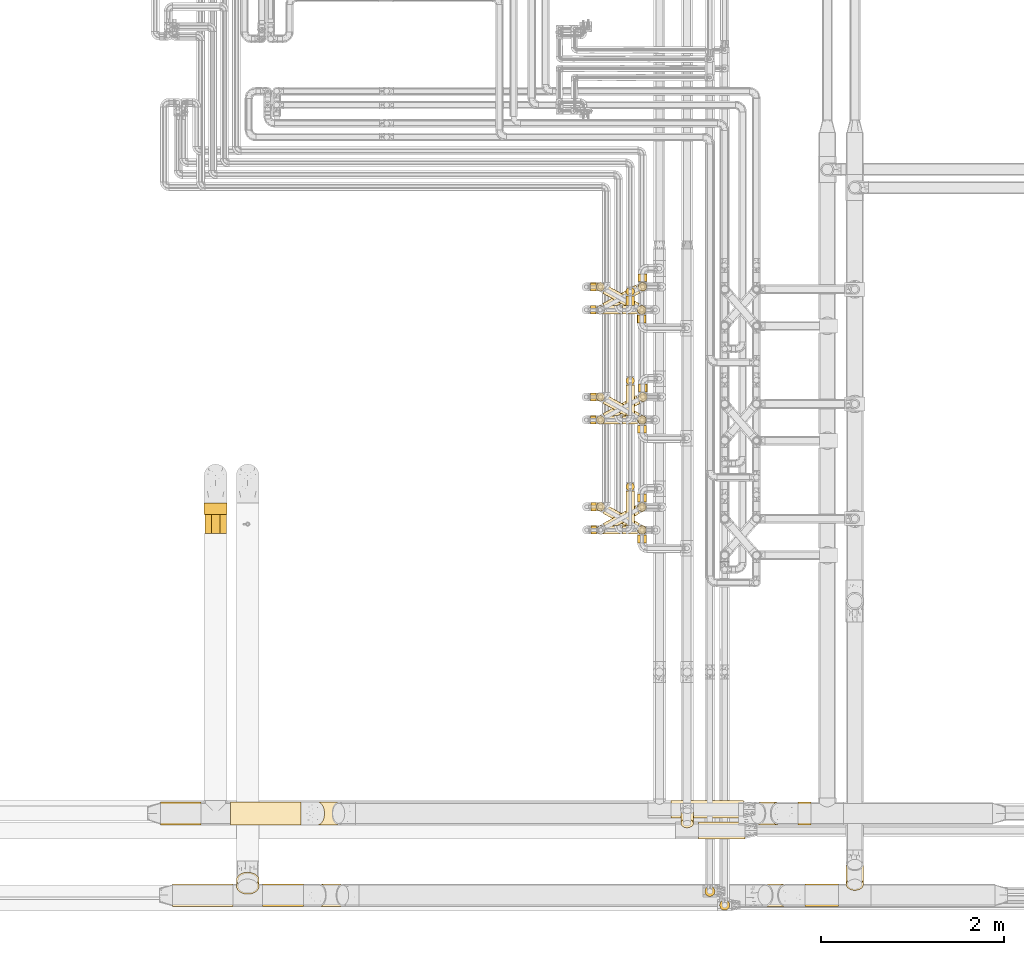
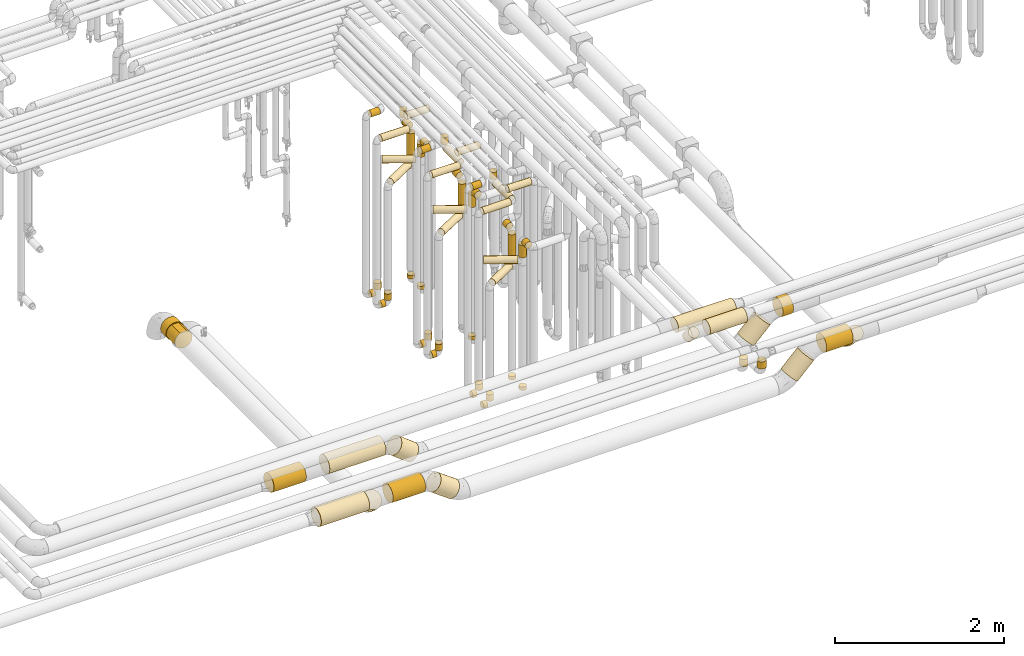
# One storey, part 11 of 824: 69 coverings.
"""IFC2X3 building model written with IfcOpenShell, lengths in millimetres."""

from ifc_helpers import new_model, entity, si_unit, converted_unit, derived_unit, direction, frame, frame_2d, origin, origin_2d_with_axis, place, context, subcontext, project, spatial, polyline, circle_curve, parameter, trimmed, segment, composite_curve, circle, outline, extrude, element, save


model = new_model("IFC2X3")

# Units and contexts
model_context = context("Model", 3, precision=0.01, world=origin(), true_north=direction((6.12303176911189e-17, 1.0)))
body_context = subcontext(model_context, "Body", "Model", "MODEL_VIEW")
ifc_project = project(units=[si_unit("LENGTHUNIT", "METRE", prefix="MILLI"), si_unit("AREAUNIT", "SQUARE_METRE"), si_unit("VOLUMEUNIT", "CUBIC_METRE"), converted_unit("PLANEANGLEUNIT", "DEGREE", entity("IfcRatioMeasure", 0.0174532925199433), si_unit("PLANEANGLEUNIT", "RADIAN"), dimensions=[0, 0, 0, 0, 0, 0, 0]), si_unit("MASSUNIT", "GRAM", prefix="KILO"), derived_unit("MASSDENSITYUNIT", [(si_unit("MASSUNIT", "GRAM", prefix="KILO"), 1), (si_unit("LENGTHUNIT", "METRE"), -3)]), derived_unit("MOMENTOFINERTIAUNIT", [(si_unit("LENGTHUNIT", "METRE"), 4)]), si_unit("TIMEUNIT", "SECOND"), si_unit("FREQUENCYUNIT", "HERTZ"), si_unit("THERMODYNAMICTEMPERATUREUNIT", "DEGREE_CELSIUS"), derived_unit("THERMALTRANSMITTANCEUNIT", [(si_unit("MASSUNIT", "GRAM", prefix="KILO"), 1), (si_unit("THERMODYNAMICTEMPERATUREUNIT", "KELVIN"), -1), (si_unit("TIMEUNIT", "SECOND"), -3)]), derived_unit("VOLUMETRICFLOWRATEUNIT", [(si_unit("LENGTHUNIT", "METRE"), 3), (si_unit("TIMEUNIT", "SECOND"), -1)]), derived_unit("MASSFLOWRATEUNIT", [(si_unit("MASSUNIT", "GRAM", prefix="KILO"), 1), (si_unit("TIMEUNIT", "SECOND"), -1)]), derived_unit("ROTATIONALFREQUENCYUNIT", [(si_unit("TIMEUNIT", "SECOND"), -1)]), si_unit("ELECTRICCURRENTUNIT", "AMPERE"), si_unit("ELECTRICVOLTAGEUNIT", "VOLT"), si_unit("POWERUNIT", "WATT"), si_unit("FORCEUNIT", "NEWTON", prefix="KILO"), si_unit("ILLUMINANCEUNIT", "LUX"), si_unit("LUMINOUSFLUXUNIT", "LUMEN"), si_unit("LUMINOUSINTENSITYUNIT", "CANDELA"), derived_unit("USERDEFINED", [(si_unit("MASSUNIT", "GRAM", prefix="KILO"), -1), (si_unit("LENGTHUNIT", "METRE"), -2), (si_unit("TIMEUNIT", "SECOND"), 3), (si_unit("LUMINOUSFLUXUNIT", "LUMEN"), 1)]), derived_unit("LINEARVELOCITYUNIT", [(si_unit("LENGTHUNIT", "METRE"), 1), (si_unit("TIMEUNIT", "SECOND"), -1)]), si_unit("PRESSUREUNIT", "PASCAL"), derived_unit("USERDEFINED", [(si_unit("LENGTHUNIT", "METRE"), -2), (si_unit("MASSUNIT", "GRAM", prefix="KILO"), 1), (si_unit("TIMEUNIT", "SECOND"), -2)]), derived_unit("LINEARFORCEUNIT", [(si_unit("MASSUNIT", "GRAM", prefix="KILO"), 1), (si_unit("LENGTHUNIT", "METRE"), 1), (si_unit("TIMEUNIT", "SECOND"), -2), (si_unit("LENGTHUNIT", "METRE"), -1)]), derived_unit("PLANARFORCEUNIT", [(si_unit("MASSUNIT", "GRAM", prefix="KILO"), 1), (si_unit("LENGTHUNIT", "METRE"), 1), (si_unit("TIMEUNIT", "SECOND"), -2), (si_unit("LENGTHUNIT", "METRE"), -2)])], contexts=[model_context])

# Site, building, storey
site_placement = place(None, origin())
site = spatial("IfcSite", under=ifc_project, at=site_placement, CompositionType="ELEMENT")
building_placement = place(site_placement, origin())
building = spatial("IfcBuilding", under=site, at=building_placement, CompositionType="ELEMENT")
storey_placement = place(building_placement, frame((0.0, 0.0, 28200.0)))
storey = spatial("IfcBuildingStorey", under=building, at=storey_placement, CompositionType="ELEMENT", Elevation=28200.0)

# Coverings
covering_1_placement = place(storey_placement, frame((35168.03, 11508.46, 352.25)))
element("IfcCovering", 1, at=covering_1_placement, inside=storey, PredefinedType="INSULATION", context=body_context, shape_type="SweptSolid", body=[
    extrude(circle(Radius=46.15, at=origin_2d_with_axis()), frame((0.0, 47.75, 47.75), z_axis=(1.0, 0.0, 0.0), x_axis=(0.0, 1.0, 0.0)), (0.0, 0.0, 1.0), 59.0000000000126),
])
covering_2_placement = place(storey_placement, frame((35227.29, 11508.46, 448.0)))
element("IfcCovering", 2, at=covering_2_placement, inside=storey, PredefinedType="INSULATION", context=body_context, shape_type="SweptSolid", body=[
    extrude(circle(Radius=46.15, at=origin_2d_with_axis()), frame((47.75, 47.75, 0.0), z_axis=(0.0, 0.0, 1.0), x_axis=(0.0, 1.0, 0.0)), (0.0, 0.0, 1.0), 92.0000000000137),
])
covering_3_placement = place(storey_placement, frame((35173.03, 10309.34, 352.25)))
element("IfcCovering", 3, at=covering_3_placement, inside=storey, PredefinedType="INSULATION", context=body_context, shape_type="SweptSolid", body=[
    extrude(circle(Radius=46.15, at=origin_2d_with_axis()), frame((0.0, 47.75, 47.75), z_axis=(1.0, 0.0, 0.0), x_axis=(0.0, 1.0, 0.0)), (0.0, 0.0, 1.0), 57.8337402419765),
])
covering_4_placement = place(storey_placement, frame((35231.12, 10309.34, 448.0)))
element("IfcCovering", 4, at=covering_4_placement, inside=storey, PredefinedType="INSULATION", context=body_context, shape_type="SweptSolid", body=[
    extrude(circle(Radius=46.15, at=origin_2d_with_axis()), frame((47.75, 47.75, 0.0), z_axis=(0.0, 0.0, 1.0), x_axis=(0.0, 1.0, 0.0)), (0.0, 0.0, 1.0), 92.0000000000137),
])
covering_5_placement = place(storey_placement, frame((35680.3, 10558.46, 448.0)))
element("IfcCovering", 5, at=covering_5_placement, inside=storey, PredefinedType="INSULATION", context=body_context, shape_type="SweptSolid", body=[
    extrude(circle(Radius=46.15, at=origin_2d_with_axis()), frame((47.75, 47.75, 0.0), z_axis=(0.0, 0.0, 1.0), x_axis=(0.0, -1.0, 0.0)), (0.0, 0.0, 1.0), 47.000000000011),
])
covering_6_placement = place(storey_placement, frame((35168.03, 11508.44, 2952.25)))
element("IfcCovering", 6, at=covering_6_placement, inside=storey, PredefinedType="INSULATION", context=body_context, shape_type="SweptSolid", body=[
    extrude(circle(Radius=46.15, at=origin_2d_with_axis()), frame((0.0, 47.76, 47.75), z_axis=(1.0, -4.58022354030143e-05, 0.0), x_axis=(-4.58022354030143e-05, -1.0, 0.0)), (0.0, 0.0, 1.0), 384.054937940216),
])
covering_7_placement = place(storey_placement, frame((35552.35, 11604.18, 2952.25)))
element("IfcCovering", 7, at=covering_7_placement, inside=storey, PredefinedType="INSULATION", context=body_context, shape_type="SweptSolid", body=[
    extrude(circle(Radius=46.15, at=origin_2d_with_axis()), frame((47.75, 0.0, 47.75), z_axis=(0.0, 1.0, 0.0), x_axis=(1.0, 0.0, 0.0)), (0.0, 0.0, 1.0), 331.019903361197),
])
covering_8_placement = place(storey_placement, frame((35552.35, 11935.46, 3048.0)))
element("IfcCovering", 8, at=covering_8_placement, inside=storey, PredefinedType="INSULATION", context=body_context, shape_type="SweptSolid", body=[
    extrude(circle(Radius=46.15, at=origin_2d_with_axis()), frame((47.75, 47.75, 0.0), z_axis=(0.0, 0.0, 1.0), x_axis=(-1.0, 0.0, 0.0)), (0.0, 0.0, 1.0), 104.000000000011),
])
covering_9_placement = place(storey_placement, frame((35677.45, 10555.61, 2157.0)))
element("IfcCovering", 9, at=covering_9_placement, inside=storey, PredefinedType="INSULATION", context=body_context, shape_type="SweptSolid", body=[
    extrude(circle(Radius=49.0, at=origin_2d_with_axis()), frame((50.6, 50.6, 0.0)), (0.0, 0.0, 1.0), 385.99999999999),
])
covering_10_placement = place(storey_placement, frame((35303.27, 10340.38, 2049.4)))
element("IfcCovering", 10, at=covering_10_placement, inside=storey, PredefinedType="INSULATION", context=body_context, shape_type="SweptSolid", body=[
    extrude(circle(Radius=49.0, at=origin_2d_with_axis()), frame((25.41, 44.42, 50.6), z_axis=(0.873900740639492, 0.486104408033651, 0.0), x_axis=(0.486104408033651, -0.873900740639492, 0.0)), (0.0, 0.0, 1.0), 399.639020319073),
])
covering_11_placement = place(storey_placement, frame((35677.45, 10663.2, 2549.4)))
element("IfcCovering", 11, at=covering_11_placement, inside=storey, PredefinedType="INSULATION", context=body_context, shape_type="SweptSolid", body=[
    extrude(circle(Radius=49.0, at=origin_2d_with_axis()), frame((50.6, 0.0, 50.6), z_axis=(0.0, 1.0, 0.0), x_axis=(-1.0, 0.0, 0.0)), (0.0, 0.0, 1.0), 85.9999999262502),
])
covering_12_placement = place(storey_placement, frame((35686.28, 11755.09, 2157.0)))
element("IfcCovering", 12, at=covering_12_placement, inside=storey, PredefinedType="INSULATION", context=body_context, shape_type="SweptSolid", body=[
    extrude(circle(Radius=49.0, at=origin_2d_with_axis()), frame((50.58, 50.58, 0.0), z_axis=(0.0, 0.0, 1.0), x_axis=(0.47617625102764, -0.879349860952546, 0.0)), (0.0, 0.0, 1.0), 385.99999999999),
])
covering_13_placement = place(storey_placement, frame((35300.25, 11538.06, 2049.4)))
element("IfcCovering", 13, at=covering_13_placement, inside=storey, PredefinedType="INSULATION", context=body_context, shape_type="SweptSolid", body=[
    extrude(circle(Radius=49.0, at=origin_2d_with_axis()), frame((24.93, 44.68, 50.6), z_axis=(0.879349860952551, 0.47617625102763, 0.0), x_axis=(-0.47617625102763, 0.879349860952551, 0.0)), (0.0, 0.0, 1.0), 411.156212335708),
])
covering_14_placement = place(storey_placement, frame((35686.26, 11862.67, 2549.4)))
element("IfcCovering", 14, at=covering_14_placement, inside=storey, PredefinedType="INSULATION", context=body_context, shape_type="SweptSolid", body=[
    extrude(circle(Radius=49.0, at=origin_2d_with_axis()), frame((50.6, 0.0, 50.6), z_axis=(0.0, 1.0, 0.0), x_axis=(-1.0, 0.0, 0.0)), (0.0, 0.0, 1.0), 86.4113062809591),
])
covering_15_placement = place(storey_placement, frame((35683.56, 12960.1, 2157.0)))
element("IfcCovering", 15, at=covering_15_placement, inside=storey, PredefinedType="INSULATION", context=body_context, shape_type="SweptSolid", body=[
    extrude(circle(Radius=49.0, at=origin_2d_with_axis()), frame((50.58, 50.58, 0.0), z_axis=(0.0, 0.0, 1.0), x_axis=(0.47617625102764, -0.879349860952546, 0.0)), (0.0, 0.0, 1.0), 385.999999999986),
])
covering_16_placement = place(storey_placement, frame((35297.3, 12738.15, 2049.4)))
element("IfcCovering", 16, at=covering_16_placement, inside=storey, PredefinedType="INSULATION", context=body_context, shape_type="SweptSolid", body=[
    extrude(circle(Radius=49.0, at=origin_2d_with_axis()), frame((25.41, 44.42, 50.6), z_axis=(0.873900740639491, 0.486104408033654, 0.0), x_axis=(-0.486104408033654, 0.873900740639491, 0.0)), (0.0, 0.0, 1.0), 413.435297220392),
])
covering_17_placement = place(storey_placement, frame((35683.65, 13067.49, 2549.4)))
element("IfcCovering", 17, at=covering_17_placement, inside=storey, PredefinedType="INSULATION", context=body_context, shape_type="SweptSolid", body=[
    extrude(circle(Radius=49.0, at=origin_2d_with_axis()), frame((50.6, 0.0, 50.6), z_axis=(0.0, 1.0, 0.0), x_axis=(-1.0, 0.0, 0.0)), (0.0, 0.0, 1.0), 81.5902938725307),
])
covering_18_placement = place(storey_placement, frame((35552.35, 10780.63, 3248.0)))
element("IfcCovering", 18, at=covering_18_placement, inside=storey, PredefinedType="INSULATION", context=body_context, shape_type="SweptSolid", body=[
    extrude(circle(Radius=46.15, at=origin_2d_with_axis()), frame((47.75, 47.75, 0.0), z_axis=(0.0, 0.0, 1.0), x_axis=(-1.0, 0.0, 0.0)), (0.0, 0.0, 1.0), 103.999999999998),
])
covering_19_placement = place(storey_placement, frame((35552.35, 10405.08, 3152.25)))
element("IfcCovering", 19, at=covering_19_placement, inside=storey, PredefinedType="INSULATION", context=body_context, shape_type="SweptSolid", body=[
    extrude(circle(Radius=46.15, at=origin_2d_with_axis()), frame((47.75, 0.0, 47.75), z_axis=(0.0, 1.0, 0.0), x_axis=(-1.0, 0.0, 0.0)), (0.0, 0.0, 1.0), 375.292233723899),
])
covering_20_placement = place(storey_placement, frame((35173.03, 10309.34, 3152.25)))
element("IfcCovering", 20, at=covering_20_placement, inside=storey, PredefinedType="INSULATION", context=body_context, shape_type="SweptSolid", body=[
    extrude(circle(Radius=46.15, at=origin_2d_with_axis()), frame((0.0, 47.75, 47.75), z_axis=(1.0, 0.0, 0.0), x_axis=(0.0, 1.0, 0.0)), (0.0, 0.0, 1.0), 379.057450000017),
])
covering_21_placement = place(storey_placement, frame((35168.03, 11758.46, 352.25)))
element("IfcCovering", 21, at=covering_21_placement, inside=storey, PredefinedType="INSULATION", context=body_context, shape_type="SweptSolid", body=[
    extrude(circle(Radius=46.15, at=origin_2d_with_axis()), frame((0.0, 47.75, 47.75), z_axis=(1.0, 0.0, 0.0), x_axis=(0.0, 1.0, 0.0)), (0.0, 0.0, 1.0), 60.205336192978),
])
covering_22_placement = place(storey_placement, frame((35228.49, 11758.46, 448.0)))
element("IfcCovering", 22, at=covering_22_placement, inside=storey, PredefinedType="INSULATION", context=body_context, shape_type="SweptSolid", body=[
    extrude(circle(Radius=46.15, at=origin_2d_with_axis()), frame((47.75, 47.75, 0.0), z_axis=(0.0, 0.0, 1.0), x_axis=(0.0, 1.0, 0.0)), (0.0, 0.0, 1.0), 92.0000000000094),
])
covering_23_placement = place(storey_placement, frame((35681.04, 11508.42, 447.94)))
element("IfcCovering", 23, at=covering_23_placement, inside=storey, PredefinedType="INSULATION", context=body_context, shape_type="SweptSolid", body=[
    extrude(circle(Radius=46.15, at=origin_2d_with_axis()), frame((47.75, 47.75, 0.06), z_axis=(0.0, 0.00137558663897165, 0.999999053880252), x_axis=(0.0, 0.999999053880252, -0.00137558663897165)), (0.0, 0.0, 1.0), 47.0000771237188),
])
covering_24_placement = place(storey_placement, frame((35173.03, 10561.4, 352.25)))
element("IfcCovering", 24, at=covering_24_placement, inside=storey, PredefinedType="INSULATION", context=body_context, shape_type="SweptSolid", body=[
    extrude(circle(Radius=46.15, at=origin_2d_with_axis()), frame((0.0, 47.75, 47.75), z_axis=(1.0, 0.0, 0.0), x_axis=(0.0, 1.0, 0.0)), (0.0, 0.0, 1.0), 55.7044279710415),
])
covering_25_placement = place(storey_placement, frame((35228.99, 10561.4, 448.0)))
element("IfcCovering", 25, at=covering_25_placement, inside=storey, PredefinedType="INSULATION", context=body_context, shape_type="SweptSolid", body=[
    extrude(circle(Radius=46.15, at=origin_2d_with_axis()), frame((47.75, 47.75, 0.0), z_axis=(0.0, 0.0, 1.0), x_axis=(0.0, 1.0, 0.0)), (0.0, 0.0, 1.0), 92.0000000000094),
])
covering_26_placement = place(storey_placement, frame((35680.3, 10308.42, 448.0)))
element("IfcCovering", 26, at=covering_26_placement, inside=storey, PredefinedType="INSULATION", context=body_context, shape_type="SweptSolid", body=[
    extrude(circle(Radius=46.15, at=origin_2d_with_axis()), frame((47.75, 47.75, 0.0), z_axis=(0.0, 0.0, 1.0), x_axis=(0.0, -1.0, 0.0)), (0.0, 0.0, 1.0), 47.0000000000153),
])
covering_27_placement = place(storey_placement, frame((36344.03, 6983.4, 3003.4)))
element("IfcCovering", 27, at=covering_27_placement, inside=storey, PredefinedType="INSULATION", context=body_context, shape_type="SweptSolid", body=[
    extrude(circle(Radius=95.0, at=origin_2d_with_axis()), frame((0.0, 96.6, 96.6), z_axis=(1.0, 0.0, 0.0), x_axis=(0.0, -1.0, 0.0)), (0.0, 0.0, 1.0), 508.799297490111),
])
covering_28_placement = place(storey_placement, frame((35168.03, 11758.46, 3152.25)))
element("IfcCovering", 28, at=covering_28_placement, inside=storey, PredefinedType="INSULATION", context=body_context, shape_type="SweptSolid", body=[
    extrude(circle(Radius=46.15, at=origin_2d_with_axis()), frame((0.0, 47.75, 47.75), z_axis=(1.0, 0.0, 0.0), x_axis=(0.0, 1.0, 0.0)), (0.0, 0.0, 1.0), 124.000000000024),
])
covering_29_placement = place(storey_placement, frame((35518.03, 11508.42, 3152.25)))
element("IfcCovering", 29, at=covering_29_placement, inside=storey, PredefinedType="INSULATION", context=body_context, shape_type="SweptSolid", body=[
    extrude(circle(Radius=46.15, at=origin_2d_with_axis()), frame((0.0, 47.75, 47.75), z_axis=(1.0, 0.0, 0.0), x_axis=(0.0, -1.0, 0.0)), (0.0, 0.0, 1.0), 307.750000000047),
])
covering_30_placement = place(storey_placement, frame((35677.45, 10305.57, 2362.0)))
element("IfcCovering", 30, at=covering_30_placement, inside=storey, PredefinedType="INSULATION", context=body_context, shape_type="SweptSolid", body=[
    extrude(circle(Radius=49.0, at=origin_2d_with_axis()), frame((50.6, 50.6, 0.0)), (0.0, 0.0, 1.0), 181.000000000002),
])
covering_31_placement = place(storey_placement, frame((35300.91, 10339.7, 2254.4)))
element("IfcCovering", 31, at=covering_31_placement, inside=storey, PredefinedType="INSULATION", context=body_context, shape_type="SweptSolid", body=[
    extrude(circle(Radius=49.0, at=origin_2d_with_axis()), frame((25.55, 241.55, 50.6), z_axis=(0.872328835264981, -0.488919628533404, 0.0), x_axis=(-0.488919628533404, -0.872328835264981, 0.0)), (0.0, 0.0, 1.0), 403.365689374244),
])
covering_32_placement = place(storey_placement, frame((35677.45, 10213.2, 2549.4)))
element("IfcCovering", 32, at=covering_32_placement, inside=storey, PredefinedType="INSULATION", context=body_context, shape_type="SweptSolid", body=[
    extrude(circle(Radius=49.0, at=origin_2d_with_axis()), frame((50.6, 0.0, 50.6), z_axis=(0.0, 1.0, 0.0), x_axis=(1.0, 0.0, 0.0)), (0.0, 0.0, 1.0), 85.9654132835041),
])
covering_33_placement = place(storey_placement, frame((35678.19, 11503.87, 2362.0)))
element("IfcCovering", 33, at=covering_33_placement, inside=storey, PredefinedType="INSULATION", context=body_context, shape_type="SweptSolid", body=[
    extrude(circle(Radius=49.0, at=origin_2d_with_axis()), frame((50.59, 50.59, 0.0), z_axis=(0.0, 0.0, 1.0), x_axis=(-0.494757339901244, -0.869031170104873, 0.0)), (0.0, 0.0, 1.0), 180.999999999998),
])
covering_34_placement = place(storey_placement, frame((35300.46, 11538.31, 2254.4)))
element("IfcCovering", 34, at=covering_34_placement, inside=storey, PredefinedType="INSULATION", context=body_context, shape_type="SweptSolid", body=[
    extrude(circle(Radius=49.0, at=origin_2d_with_axis()), frame((25.52, 241.99, 50.6), z_axis=(0.872709848733326, -0.488239203591698, 0.0), x_axis=(0.488239203591698, 0.872709848733326, 0.0)), (0.0, 0.0, 1.0), 404.791381976554),
])
covering_35_placement = place(storey_placement, frame((35678.19, 11413.08, 2549.4)))
element("IfcCovering", 35, at=covering_35_placement, inside=storey, PredefinedType="INSULATION", context=body_context, shape_type="SweptSolid", body=[
    extrude(circle(Radius=49.0, at=origin_2d_with_axis()), frame((50.6, 0.0, 50.6), z_axis=(0.0, 1.0, 0.0), x_axis=(1.0, 0.0, 0.0)), (0.0, 0.0, 1.0), 84.3822522691391),
])
covering_36_placement = place(storey_placement, frame((35674.65, 12704.08, 2362.0)))
element("IfcCovering", 36, at=covering_36_placement, inside=storey, PredefinedType="INSULATION", context=body_context, shape_type="SweptSolid", body=[
    extrude(circle(Radius=49.0, at=origin_2d_with_axis()), frame((50.38, 50.38, 0.0), z_axis=(0.0, 0.0, 1.0), x_axis=(-0.579093053123268, -0.81526145243374, 0.0)), (0.0, 0.0, 1.0), 180.999999999993),
])
covering_37_placement = place(storey_placement, frame((35299.57, 12738.31, 2254.4)))
element("IfcCovering", 37, at=covering_37_placement, inside=storey, PredefinedType="INSULATION", context=body_context, shape_type="SweptSolid", body=[
    extrude(circle(Radius=49.0, at=origin_2d_with_axis()), frame((25.52, 240.4, 50.6), z_axis=(0.872709832917215, -0.488239231862421, 0.0), x_axis=(0.488239231862421, 0.872709832917215, 0.0)), (0.0, 0.0, 1.0), 401.518720143664),
])
covering_38_placement = place(storey_placement, frame((35674.44, 12613.08, 2549.4)))
element("IfcCovering", 38, at=covering_38_placement, inside=storey, PredefinedType="INSULATION", context=body_context, shape_type="SweptSolid", body=[
    extrude(circle(Radius=49.0, at=origin_2d_with_axis()), frame((50.6, 0.0, 50.6), z_axis=(0.0, 1.0, 0.0), x_axis=(1.0, 0.0, 0.0)), (0.0, 0.0, 1.0), 84.38225226915),
])
covering_39_placement = place(storey_placement, frame((35173.03, 10561.4, 3352.25)))
element("IfcCovering", 39, at=covering_39_placement, inside=storey, PredefinedType="INSULATION", context=body_context, shape_type="SweptSolid", body=[
    extrude(circle(Radius=46.15, at=origin_2d_with_axis()), frame((0.0, 47.75, 47.75), z_axis=(1.0, 0.0, 0.0), x_axis=(0.0, 1.0, 0.0)), (0.0, 0.0, 1.0), 119.000000000016),
])
covering_40_placement = place(storey_placement, frame((35518.03, 10308.42, 3352.25)))
element("IfcCovering", 40, at=covering_40_placement, inside=storey, PredefinedType="INSULATION", context=body_context, shape_type="SweptSolid", body=[
    extrude(circle(Radius=46.15, at=origin_2d_with_axis()), frame((0.0, 47.75, 47.75), z_axis=(1.0, 0.0, 0.0), x_axis=(0.0, 1.0, 0.0)), (0.0, 0.0, 1.0), 312.75000000005),
])
covering_41_placement = place(storey_placement, frame((35168.03, 12708.46, 352.25)))
element("IfcCovering", 41, at=covering_41_placement, inside=storey, PredefinedType="INSULATION", context=body_context, shape_type="SweptSolid", body=[
    extrude(circle(Radius=46.15, at=origin_2d_with_axis()), frame((0.0, 47.75, 47.75), z_axis=(1.0, 0.0, 0.0), x_axis=(0.0, 1.0, 0.0)), (0.0, 0.0, 1.0), 56.8702533571783),
])
covering_42_placement = place(storey_placement, frame((35225.16, 12708.46, 448.0)))
element("IfcCovering", 42, at=covering_42_placement, inside=storey, PredefinedType="INSULATION", context=body_context, shape_type="SweptSolid", body=[
    extrude(circle(Radius=46.15, at=origin_2d_with_axis()), frame((47.75, 47.75, 0.0), z_axis=(0.0, 0.0, 1.0), x_axis=(0.0, 1.0, 0.0)), (0.0, 0.0, 1.0), 92.0000000000094),
])
covering_43_placement = place(storey_placement, frame((35552.35, 12908.43, 2847.61)))
element("IfcCovering", 43, at=covering_43_placement, inside=storey, PredefinedType="INSULATION", context=body_context, shape_type="SweptSolid", body=[
    extrude(circle(Radius=46.15, at=origin_2d_with_axis()), frame((47.75, 47.75, 0.0), z_axis=(0.0, 0.0, 1.0), x_axis=(-1.0, 0.0, 0.0)), (0.0, 0.0, 1.0), 104.39114387437),
])
covering_44_placement = place(storey_placement, frame((35552.35, 12804.17, 2751.86)))
element("IfcCovering", 44, at=covering_44_placement, inside=storey, PredefinedType="INSULATION", context=body_context, shape_type="SweptSolid", body=[
    extrude(circle(Radius=46.15, at=origin_2d_with_axis()), frame((47.75, 0.0, 47.75), z_axis=(0.0, 1.0, 0.0), x_axis=(1.0, 0.0, 0.0)), (0.0, 0.0, 1.0), 104.000000000018),
])
covering_45_placement = place(storey_placement, frame((35168.03, 12708.43, 2751.86)))
element("IfcCovering", 45, at=covering_45_placement, inside=storey, PredefinedType="INSULATION", context=body_context, shape_type="SweptSolid", body=[
    extrude(circle(Radius=46.15, at=origin_2d_with_axis()), frame((0.0, 47.77, 47.75), z_axis=(0.999999997789185, -6.64953413086212e-05, 0.0), x_axis=(6.64953413086212e-05, 0.999999997789185, 0.0)), (0.0, 0.0, 1.0), 384.054259178842),
])
covering_46_placement = place(storey_placement, frame((35518.03, 12708.42, 2952.25)))
element("IfcCovering", 46, at=covering_46_placement, inside=storey, PredefinedType="INSULATION", context=body_context, shape_type="SweptSolid", body=[
    extrude(circle(Radius=46.15, at=origin_2d_with_axis()), frame((0.0, 47.75, 47.75), z_axis=(1.0, 0.0, 0.0), x_axis=(0.0, 1.0, 0.0)), (0.0, 0.0, 1.0), 307.750000000012),
])
for number, where in (
    (47, (35677.29, 12708.42, 448.0)),
    (48, (35686.39, 12958.46, 448.0)),
):
    element("IfcCovering", number, at=place(storey_placement, frame(where)), inside=storey, PredefinedType="INSULATION", context=body_context, shape_type="SweptSolid", body=[
        extrude(circle(Radius=46.15, at=origin_2d_with_axis()), frame((47.75, 47.75, 0.0), z_axis=(0.0, 0.0, 1.0), x_axis=(0.0, -1.0, 0.0)), (0.0, 0.0, 1.0), 47.000000000011),
    ])
covering_47_placement = place(storey_placement, frame((35168.03, 12958.46, 2952.25)))
element("IfcCovering", 49, at=covering_47_placement, inside=storey, PredefinedType="INSULATION", context=body_context, shape_type="SweptSolid", body=[
    extrude(circle(Radius=46.15, at=origin_2d_with_axis()), frame((0.0, 47.75, 47.75), z_axis=(1.0, 0.0, 0.0), x_axis=(0.0, -1.0, 0.0)), (0.0, 0.0, 1.0), 124.000000000015),
])
covering_48_placement = place(storey_placement, frame((35168.03, 12958.46, 352.25)))
element("IfcCovering", 50, at=covering_48_placement, inside=storey, PredefinedType="INSULATION", context=body_context, shape_type="SweptSolid", body=[
    extrude(circle(Radius=46.15, at=origin_2d_with_axis()), frame((0.0, 47.75, 47.75), z_axis=(1.0, 0.0, 0.0), x_axis=(0.0, 1.0, 0.0)), (0.0, 0.0, 1.0), 59.3114268710131),
])
covering_49_placement = place(storey_placement, frame((35227.6, 12958.46, 448.0)))
element("IfcCovering", 51, at=covering_49_placement, inside=storey, PredefinedType="INSULATION", context=body_context, shape_type="SweptSolid", body=[
    extrude(circle(Radius=46.15, at=origin_2d_with_axis()), frame((47.75, 47.75, 0.0), z_axis=(0.0, 0.0, 1.0), x_axis=(0.0, 1.0, 0.0)), (0.0, 0.0, 1.0), 92.0000000000094),
])
covering_50_placement = place(storey_placement, frame((30953.9, 10524.83, 2673.9)))
element("IfcCovering", 52, at=covering_50_placement, inside=storey, PredefinedType="INSULATION", context=body_context, shape_type="SweptSolid", body=[
    extrude(outline(polyline([(-16.25, -123.43), (16.25, -123.43), (47.64, -115.02), (75.79, -98.77), (98.77, -75.79), (115.02, -47.64), (123.43, -16.25), (123.43, 16.25), (115.02, 47.64), (98.77, 75.79), (75.79, 98.77), (47.64, 115.02), (16.25, 123.43), (-16.25, 123.43), (-47.64, 115.02), (-75.79, 98.77), (-98.77, 75.79), (-115.02, 47.64), (-123.43, 16.25), (-123.43, -16.25), (-115.02, -47.64), (-98.77, -75.79), (-75.79, -98.77), (-47.64, -115.02), (-16.25, -123.43)])), frame((126.1, 0.0, 126.1), z_axis=(3.15716611416897e-09, 1.0, 0.0), x_axis=(-0.130526192220075, 0.0, -0.991444861373807)), (0.0, 0.0, 1.0), 125.173920988328),
])
covering_51_placement = place(storey_placement, frame((30479.76, 7140.11, 2673.9)))
element("IfcCovering", 53, at=covering_51_placement, inside=storey, PredefinedType="INSULATION", context=body_context, shape_type="SweptSolid", body=[
    extrude(circle(Radius=124.5, at=origin_2d_with_axis()), frame((0.0, 126.1, 126.1), z_axis=(1.0, 0.0, -2.62756642280565e-06), x_axis=(0.0, -1.0, 0.0)), (0.0, 0.0, 1.0), 440.240643086704),
])
covering_52_placement = place(storey_placement, frame((31240.0, 7140.11, 2673.9)))
element("IfcCovering", 54, at=covering_52_placement, inside=storey, PredefinedType="INSULATION", context=body_context, shape_type="SweptSolid", body=[
    extrude(circle(Radius=124.5, at=origin_2d_with_axis()), frame((0.0, 126.1, 126.1), z_axis=(1.0, 0.0, 0.0), x_axis=(0.0, 1.0, 0.0)), (0.0, 0.0, 1.0), 768.43288548493),
])
covering_53_placement = place(storey_placement, frame((36149.19, 7107.79, 2832.83)))
element("IfcCovering", 55, at=covering_53_placement, inside=storey, PredefinedType="INSULATION", context=body_context, shape_type="SweptSolid", body=[
    extrude(circle(Radius=69.25, at=origin_2d_with_axis()), frame((70.85, 188.55, 50.56), z_axis=(0.0, -0.707106781186553, 0.707106781186542), x_axis=(-1.0, 0.0, 0.0)), (0.0, 0.0, 1.0), 195.141869989341),
])
covering_54_placement = place(storey_placement, frame((36412.12, 6359.97, 2926.0)))
element("IfcCovering", 56, at=covering_54_placement, inside=storey, PredefinedType="INSULATION", context=body_context, shape_type="SweptSolid", body=[
    extrude(circle(Radius=55.0, at=origin_2d_with_axis()), frame((56.6, 56.6, 0.0), z_axis=(0.0, 0.0, 1.0), x_axis=(0.0, -1.0, 0.0)), (0.0, 0.0, 1.0), 104.000000000007),
])
covering_55_placement = place(storey_placement, frame((36573.05, 6209.22, 2926.0)))
element("IfcCovering", 57, at=covering_55_placement, inside=storey, PredefinedType="INSULATION", context=body_context, shape_type="SweptSolid", body=[
    extrude(circle(Radius=55.0, at=origin_2d_with_axis()), frame((56.6, 56.6, 0.0), z_axis=(0.0, 0.0, 1.0), x_axis=(0.0, -1.0, 0.0)), (0.0, 0.0, 1.0), 104.000075851891),
])
covering_56_placement = place(storey_placement, frame((37426.65, 7140.11, 2773.78)))
element("IfcCovering", 58, at=covering_56_placement, inside=storey, PredefinedType="INSULATION", context=body_context, shape_type="SweptSolid", body=[
    extrude(circle(Radius=124.5, at=origin_2d_with_axis()), frame((143.64, 126.1, 126.1), z_axis=(-1.0, 0.0, 1.90022622957278e-05), x_axis=(0.0, -1.0, 0.0)), (0.0, 0.0, 1.0), 143.641200665801),
])
covering_57_placement = place(storey_placement, frame((36900.68, 7140.11, 2498.19)))
element("IfcCovering", 59, at=covering_57_placement, inside=storey, PredefinedType="INSULATION", context=body_context, shape_type="SweptSolid", body=[
    extrude(circle(Radius=124.5, at=origin_2d_with_axis()), frame((89.63, 126.1, 89.63), z_axis=(0.707128324867815, 0.0, 0.707085236848881), x_axis=(0.0, -1.0, 0.0)), (0.0, 0.0, 1.0), 317.064992744885),
])
covering_58_placement = place(storey_placement, frame((30610.11, 6248.9, 2673.9)))
element("IfcCovering", 60, at=covering_58_placement, inside=storey, PredefinedType="INSULATION", context=body_context, shape_type="SweptSolid", body=[
    extrude(circle(Radius=124.5, at=origin_2d_with_axis()), frame((0.0, 126.1, 126.1), z_axis=(1.0, 0.0, 0.0), x_axis=(0.0, -1.0, 0.0)), (0.0, 0.0, 1.0), 659.891728032664),
])
covering_59_placement = place(storey_placement, frame((31590.0, 6248.9, 2673.9)))
element("IfcCovering", 61, at=covering_59_placement, inside=storey, PredefinedType="INSULATION", context=body_context, shape_type="SweptSolid", body=[
    extrude(circle(Radius=124.5, at=origin_2d_with_axis()), frame((0.0, 126.1, 126.1), z_axis=(1.0, 0.0, 0.0), x_axis=(0.0, -0.707106781186543, -0.707106781186552)), (0.0, 0.0, 1.0), 446.080617390533),
])
covering_60_placement = place(storey_placement, frame((31303.9, 6384.36, 2548.24)))
element("IfcCovering", 62, at=covering_60_placement, inside=storey, PredefinedType="INSULATION", context=body_context, shape_type="SweptSolid", body=[
    extrude(circle(Radius=124.5, at=origin_2d_with_axis()), frame((126.1, 89.63, 152.77), z_axis=(0.0, 0.707106781186537, -0.707106781186558), x_axis=(1.0, 0.0, 0.0)), (0.0, 0.0, 1.0), 89.289321881383),
])
covering_61_placement = place(storey_placement, frame((32137.86, 6248.9, 2455.36)))
element("IfcCovering", 63, at=covering_61_placement, inside=storey, PredefinedType="INSULATION", context=body_context, shape_type="SweptSolid", body=[
    extrude(circle(Radius=124.5, at=origin_2d_with_axis()), frame((328.57, 126.1, 102.21), z_axis=(-0.808117884699288, 0.0, 0.589020784377893), x_axis=(0.0, 1.0, 0.0)), (0.0, 0.0, 1.0), 313.861133125843),
])
covering_62_placement = place(storey_placement, frame((37506.49, 6248.9, 2773.9)))
element("IfcCovering", 64, at=covering_62_placement, inside=storey, PredefinedType="INSULATION", context=body_context, shape_type="SweptSolid", body=[
    extrude(circle(Radius=124.5, at=origin_2d_with_axis()), frame((0.0, 126.1, 126.1), z_axis=(1.0, 0.0, 0.0), x_axis=(0.0, -1.0, 0.0)), (0.0, 0.0, 1.0), 363.810001287764),
])
covering_63_placement = place(storey_placement, frame((36980.46, 6248.9, 2498.24)))
element("IfcCovering", 65, at=covering_63_placement, inside=storey, PredefinedType="INSULATION", context=body_context, shape_type="SweptSolid", body=[
    extrude(circle(Radius=124.5, at=origin_2d_with_axis()), frame((89.63, 126.1, 89.63), z_axis=(0.707106792500009, 0.0, 0.707106769873086), x_axis=(0.0, -1.0, 0.0)), (0.0, 0.0, 1.0), 317.157302199656),
])
covering_64_placement = place(storey_placement, frame((37952.2, 6425.38, 2497.48)))
element("IfcCovering", 66, at=covering_64_placement, inside=storey, PredefinedType="INSULATION", context=body_context, shape_type="SweptSolid", body=[
    extrude(circle(Radius=94.5, at=origin_2d_with_axis()), frame((96.1, 283.72, 68.42), z_axis=(0.0, -0.707106781186546, 0.70710678118655), x_axis=(-1.0, 0.0, 0.0)), (0.0, 0.0, 1.0), 304.487373415325),
])
covering_65_placement = place(storey_placement, frame((36043.07, 7213.4, 3003.4)))
element("IfcCovering", 67, at=covering_65_placement, inside=storey, PredefinedType="INSULATION", context=body_context, shape_type="SweptSolid", body=[
    extrude(circle(Radius=95.0, at=origin_2d_with_axis()), frame((0.0, 96.6, 96.6), z_axis=(1.0, 0.0, 0.0), x_axis=(0.0, -1.0, 0.0)), (0.0, 0.0, 1.0), 791.966250687601),
])
covering_66_placement = place(storey_placement, frame((32113.45, 7140.11, 2461.17)))
element("IfcCovering", 68, at=covering_66_placement, inside=storey, PredefinedType="INSULATION", context=body_context, shape_type="SweptSolid", body=[
    extrude(circle(Radius=124.5, at=origin_2d_with_axis()), frame((308.18, 126.1, 100.49), z_axis=(-0.794332086218718, 0.0, 0.607483774930178), x_axis=(0.0, -1.0, 0.0)), (0.0, 0.0, 1.0), 290.756106971443),
])
covering_67_placement = place(storey_placement, frame((30960.9, 10319.83, 2680.9)))
element("IfcCovering", 69, at=covering_67_placement, inside=storey, PredefinedType="INSULATION", context=body_context, shape_type="SweptSolid", body=[
    extrude(outline(composite_curve([segment(trimmed(circle_curve(frame_2d((19.5, 0.0), x_axis=(1.0, 0.0)), 117.5), [parameter(0.0)], [parameter(90.0)], True, "PARAMETER"), True, "CONTINUOUS"), segment(trimmed(circle_curve(frame_2d((19.5, 0.0), x_axis=(1.0, 0.0)), 117.5), [parameter(90.0)], [parameter(156.190623774301)], True, "PARAMETER"), True, "CONTINUOUS"), segment(polyline([(-88.0, 47.43), (-88.0, -47.43)]), True, "CONTINUOUS"), segment(trimmed(circle_curve(frame_2d((19.5, 0.0), x_axis=(1.0, 0.0)), 117.5), [parameter(203.8093762257)], [parameter(270.0)], True, "PARAMETER"), True, "CONTINUOUS"), segment(trimmed(circle_curve(frame_2d((19.5, 0.0), x_axis=(1.0, 0.0)), 117.5), [parameter(270.0)], [parameter(0.0)], True, "PARAMETER"), True, "CONTINUOUS")], self_intersect=False)), frame((119.1, 0.0, 138.6), z_axis=(0.0, 1.0, 0.0), x_axis=(1.0136969447085e-07, 0.0, -1.0)), (0.0, 0.0, 1.0), 204.999999999997),
])

save(model, "model.ifc")
